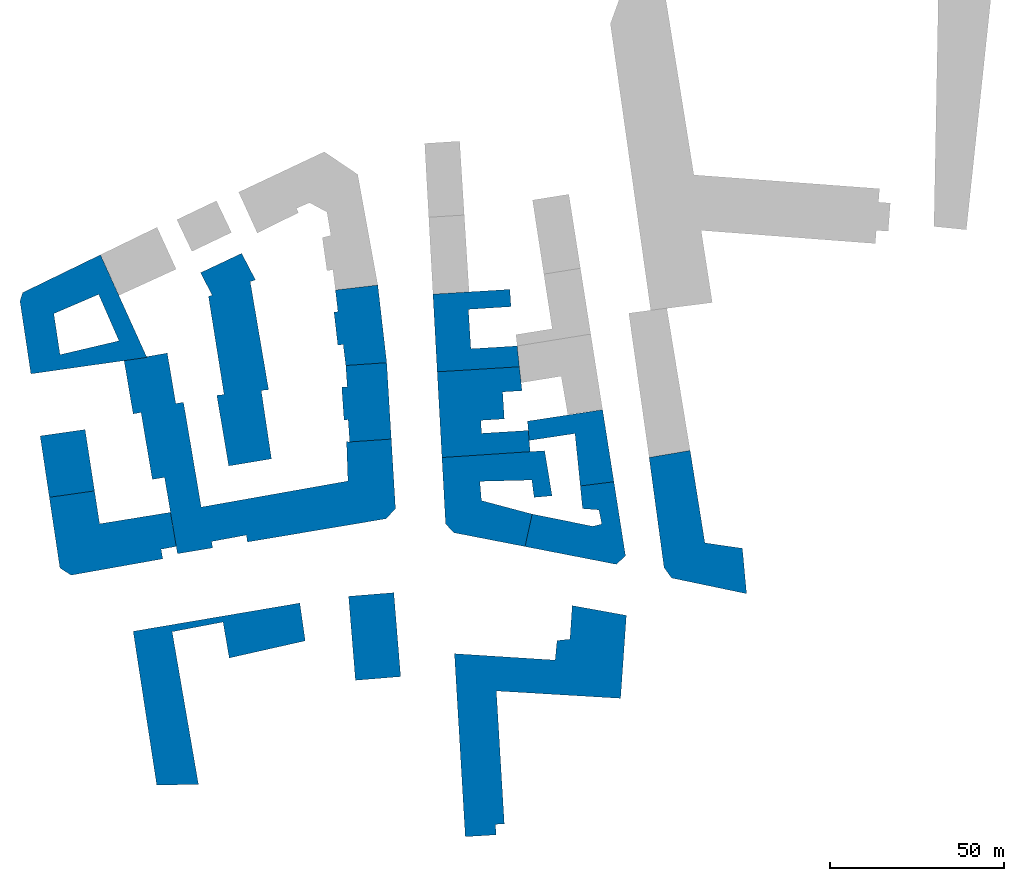
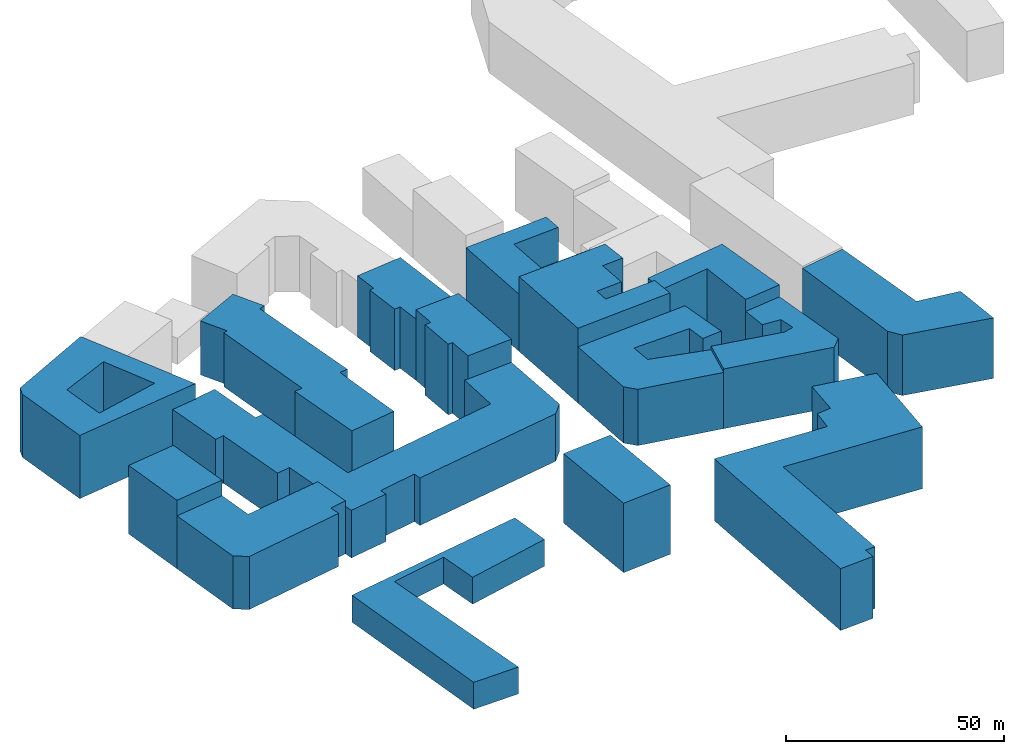
# One storey, part 1 of 2: 16 walls.
"""IFC2X3 building model written with IfcOpenShell, lengths in metres."""

from ifc_helpers import new_model, entity, si_unit, converted_unit, origin_with_axes, origin_2d_with_axis, place, context, subcontext, project, spatial, faceted_brep, element, save


model = new_model("IFC2X3")

# Units and contexts
model_context = context("Model", 3, precision=1e-05, world=origin_with_axes())
plan_context = context("Plan", 2, precision=1e-05, world=origin_2d_with_axis())
body_context = subcontext(model_context, "Body", "Model", "MODEL_VIEW")
ifc_project = project(units=[si_unit("AREAUNIT", "SQUARE_METRE"), si_unit("VOLUMEUNIT", "CUBIC_METRE"), si_unit("LENGTHUNIT", "METRE"), converted_unit("PLANEANGLEUNIT", "degree", entity("IfcReal", 0.0174532925199433), si_unit("PLANEANGLEUNIT", "RADIAN"), dimensions=[0, 0, 0, 0, 0, 0, 0])], contexts=[model_context, plan_context])

# Site, building, storey
site_placement = place(None, origin_with_axes())
site = spatial("IfcSite", under=ifc_project, at=site_placement, CompositionType="ELEMENT")
building_placement = place(site_placement, origin_with_axes())
building = spatial("IfcBuilding", under=site, at=building_placement, Name="Building", CompositionType="ELEMENT")
storey_placement = place(building_placement, origin_with_axes())
storey = spatial("IfcBuildingStorey", under=building, at=storey_placement, Name="Storey", CompositionType="ELEMENT")

# Walls
wall_1_placement = place(storey_placement, origin_with_axes())
element("IfcWall", 1, at=wall_1_placement, inside=storey, Name="map_2.buildings", context=body_context, shape_type="Brep", body=[
    faceted_brep([(58.7757415771484, -22.9065933227539, 0.0), (59.4299621582031, -29.4299068450928, 0.0), (59.4299621582031, -29.4299068450928, 16.7430152893066), (58.7757415771484, -22.9065933227539, 16.7430152893066), (68.449333190918, -21.7042007446289, 0.0), (68.449333190918, -21.7042007446289, 16.7430152893066), (71.7769470214844, -42.9439086914062, 16.7430152893066), (71.7769470214844, -42.9439086914062, 0.0), (69.2107620239258, -45.4709014892578, 16.7430152893066), (69.2107620239258, -45.4709014892578, 0.0), (42.8817558288574, -40.3394088745117, 0.0), (42.8817558288574, -40.3394088745117, 16.7430152893066), (44.9384117126465, -30.999683380127, 0.0), (44.9384117126465, -30.999683380127, 16.7430152893066), (62.3862113952637, -34.5060348510742, 0.0), (62.3862113952637, -34.5060348510742, 16.7430152893066), (64.9712905883789, -33.8603439331055, 0.0), (64.9712905883789, -33.8603439331055, 16.7430152893066), (64.140983581543, -29.7971935272217, 16.7430152893066), (64.140983581543, -29.7971935272217, 0.0)], [[[0, 1, 2, 3]], [[4, 0, 3, 5]], [[4, 6, 7]], [[7, 8, 9]], [[10, 9, 8, 11]], [[12, 10, 11, 13]], [[14, 12, 13, 15]], [[16, 14, 15, 17]], [[16, 18, 19]], [[1, 19, 18, 2]], [[4, 5, 6]], [[7, 6, 8]], [[16, 17, 18]]]),
    faceted_brep([(58.7757415771484, -22.9065933227539, 16.7430152893066), (59.4299621582031, -29.4299068450928, 16.7430152893066), (64.140983581543, -29.7971935272217, 16.7430152893066), (64.9712905883789, -33.8603439331055, 16.7430152893066), (62.3862113952637, -34.5060348510742, 16.7430152893066), (44.9384117126465, -30.999683380127, 16.7430152893066), (42.8817558288574, -40.3394088745117, 16.7430152893066), (69.2107620239258, -45.4709014892578, 16.7430152893066), (71.7769470214844, -42.9439086914062, 16.7430152893066), (68.449333190918, -21.7042007446289, 16.7430152893066)], [[[0, 1, 2, 3, 4, 5, 6, 7, 8, 9]]]),
])
wall_2_placement = place(storey_placement, origin_with_axes())
element("IfcWall", 2, at=wall_2_placement, inside=storey, Name="map_2.buildings", context=body_context, shape_type="Brep", body=[
    faceted_brep([(5.13064289093018, -53.597770690918, 0.0), (-7.88290691375732, -54.6553001403809, 0.0), (-7.88290691375732, -54.6553001403809, 19.4719886779785), (5.13064289093018, -53.597770690918, 19.4719886779785), (7.09938287734985, -77.7652282714844, 0.0), (7.09938287734985, -77.7652282714844, 19.4719886779785), (-5.90794897079468, -78.8227615356445, 19.4719886779785), (-5.90794897079468, -78.8227615356445, 0.0)], [[[0, 1, 2, 3]], [[4, 0, 3, 5]], [[4, 6, 7]], [[1, 7, 6, 2]], [[4, 5, 6]]]),
    faceted_brep([(5.13064289093018, -53.597770690918, 19.4719886779785), (-5.90794897079468, -78.8227615356445, 19.4719886779785), (7.09938287734985, -77.7652282714844, 19.4719886779785), (-7.88290691375732, -54.6553001403809, 19.4719886779785)], [[[0, 1, 2]], [[0, 3, 1]]]),
])
wall_3_placement = place(storey_placement, origin_with_axes())
element("IfcWall", 3, at=wall_3_placement, inside=storey, Name="map_2.buildings", context=body_context, shape_type="Brep", body=[
    faceted_brep([(-46.9925994873047, -40.7178535461426, 0.0), (-57.1065559387207, -42.4097900390625, 13.334171295166), (-57.1065559387207, -42.4097900390625, 0.0), (-60.8234977722168, -20.4352722167969, 13.334171295166), (-60.8234977722168, -20.4352722167969, 0.0), (-64.3331756591797, -21.0252151489258, 0.0), (-64.3331756591797, -21.0252151489258, 13.334171295166), (-67.5909576416016, -1.7780259847641, 13.334171295166), (-67.5909576416016, -1.7780259847641, 0.0), (-69.8678359985352, -2.16760802268982, 0.0), (-69.8678359985352, -2.16760802268982, 13.334171295166), (-72.4589385986328, 13.149995803833, 0.0), (-72.4589385986328, 13.149995803833, 13.334171295166), (-60.0430793762207, 15.3316698074341, 0.0), (-60.0430793762207, 15.3316698074341, 13.334171295166), (-57.5902976989746, 0.804443001747131, 0.0), (-57.5902976989746, 0.804443001747131, 13.334171295166), (-55.3826065063477, 1.17176902294159, 0.0), (-55.3826065063477, 1.17176902294159, 13.334171295166), (-50.2757186889648, -28.9847431182861, 0.0), (-50.2757186889648, -28.9847431182861, 13.334171295166), (-8.07153987884521, -21.4820919036865, 0.0), (-8.07153987884521, -21.4820919036865, 13.334171295166), (-8.46777057647705, -10.1275024414062, 0.0), (-8.46777057647705, -10.1275024414062, 13.334171295166), (-7.56205177307129, -10.238823890686, 0.0), (-7.56205177307129, -10.238823890686, 13.334171295166), (4.40727519989014, -9.41506385803223, 0.0), (4.40727519989014, -9.41506385803223, 13.334171295166), (5.61492490768433, -29.4080429077148, 0.0), (5.61492490768433, -29.4080429077148, 13.334171295166), (2.92920708656311, -32.3357467651367, 13.334171295166), (2.92920708656311, -32.3357467651367, 0.0), (-36.9792900085449, -39.0370254516602, 13.334171295166), (-36.9792900085449, -39.0370254516602, 0.0), (-37.2874717712402, -37.0444030761719, 13.334171295166), (-37.2874717712402, -37.0444030761719, 0.0), (-47.30078125, -38.8922119140625, 13.334171295166), (-47.30078125, -38.8922119140625, 0.0), (-46.9925994873047, -40.7178535461426, 13.334171295166)], [[[0, 1, 2]], [[2, 3, 4]], [[5, 4, 3, 6]], [[5, 7, 8]], [[9, 8, 7, 10]], [[11, 9, 10, 12]], [[13, 11, 12, 14]], [[15, 13, 14, 16]], [[17, 15, 16, 18]], [[19, 17, 18, 20]], [[21, 19, 20, 22]], [[23, 21, 22, 24]], [[25, 23, 24, 26]], [[27, 25, 26, 28]], [[29, 27, 28, 30]], [[29, 31, 32]], [[32, 33, 34]], [[34, 35, 36]], [[36, 37, 38]], [[38, 39, 0]], [[0, 39, 1]], [[2, 1, 3]], [[5, 6, 7]], [[29, 30, 31]], [[32, 31, 33]], [[34, 33, 35]], [[36, 35, 37]], [[38, 37, 39]]]),
    faceted_brep([(-47.30078125, -38.8922119140625, 13.334171295166), (-37.2874717712402, -37.0444030761719, 13.334171295166), (-50.2757186889648, -28.9847431182861, 13.334171295166), (-60.8234977722168, -20.4352722167969, 13.334171295166), (-57.1065559387207, -42.4097900390625, 13.334171295166), (-46.9925994873047, -40.7178535461426, 13.334171295166), (-67.5909576416016, -1.7780259847641, 13.334171295166), (-64.3331756591797, -21.0252151489258, 13.334171295166), (-72.4589385986328, 13.149995803833, 13.334171295166), (-69.8678359985352, -2.16760802268982, 13.334171295166), (-57.5902976989746, 0.804443001747131, 13.334171295166), (-60.0430793762207, 15.3316698074341, 13.334171295166), (-55.3826065063477, 1.17176902294159, 13.334171295166), (-7.56205177307129, -10.238823890686, 13.334171295166), (-8.46777057647705, -10.1275024414062, 13.334171295166), (-8.07153987884521, -21.4820919036865, 13.334171295166), (4.40727519989014, -9.41506385803223, 13.334171295166), (5.61492490768433, -29.4080429077148, 13.334171295166), (2.92920708656311, -32.3357467651367, 13.334171295166), (-36.9792900085449, -39.0370254516602, 13.334171295166)], [[[0, 1, 2]], [[3, 4, 2]], [[4, 5, 0]], [[4, 0, 2]], [[6, 7, 3]], [[8, 9, 6]], [[10, 11, 6]], [[11, 8, 6]], [[2, 12, 3]], [[12, 10, 3]], [[13, 14, 15]], [[16, 13, 15]], [[10, 6, 3]], [[17, 16, 15]], [[17, 15, 18]], [[15, 2, 1]], [[19, 18, 15]], [[1, 19, 15]]]),
])
wall_4_placement = place(storey_placement, origin_with_axes())
element("IfcWall", 4, at=wall_4_placement, inside=storey, Name="map_2.buildings", context=body_context, shape_type="Brep", body=[
    faceted_brep([(-47.1427726745605, 31.9849071502686, 0.0), (-48.1868591308594, 31.6175632476807, 0.0), (-48.1868591308594, 31.6175632476807, 15.123309135437), (-47.1427726745605, 31.9849071502686, 15.123309135437), (-50.4762115478516, 38.4414749145508, 15.123309135437), (-50.4762115478516, 38.4414749145508, 0.0), (-38.6516304016113, 44.0184593200684, 15.123309135437), (-38.6516304016113, 44.0184593200684, 0.0), (-34.670352935791, 36.381908416748, 0.0), (-34.670352935791, 36.381908416748, 15.123309135437), (-36.1798706054688, 35.8587188720703, 15.123309135437), (-36.1798706054688, 35.8587188720703, 0.0), (-30.8967876434326, 4.80054187774658, 0.0), (-30.8967876434326, 4.80054187774658, 15.123309135437), (-33.010124206543, 4.56678676605225, 0.0), (-33.010124206543, 4.56678676605225, 15.123309135437), (-30.0729751586914, -15.114520072937, 0.0), (-30.0729751586914, -15.114520072937, 15.123309135437), (-42.3819808959961, -17.1404323577881, 0.0), (-42.3819808959961, -17.1404323577881, 15.123309135437), (-45.7907981872559, 3.17540788650513, 0.0), (-45.7907981872559, 3.17540788650513, 15.123309135437), (-43.7026176452637, 3.39802598953247, 0.0), (-43.7026176452637, 3.39802598953247, 15.123309135437)], [[[0, 1, 2, 3]], [[0, 4, 5]], [[5, 6, 7]], [[8, 7, 6, 9]], [[8, 10, 11]], [[12, 11, 10, 13]], [[14, 12, 13, 15]], [[16, 14, 15, 17]], [[18, 16, 17, 19]], [[20, 18, 19, 21]], [[22, 20, 21, 23]], [[22, 2, 1]], [[0, 3, 4]], [[5, 4, 6]], [[8, 9, 10]], [[22, 23, 2]]]),
    faceted_brep([(-33.010124206543, 4.56678676605225, 15.123309135437), (-36.1798706054688, 35.8587188720703, 15.123309135437), (-47.1427726745605, 31.9849071502686, 15.123309135437), (-48.1868591308594, 31.6175632476807, 15.123309135437), (-43.7026176452637, 3.39802598953247, 15.123309135437), (-45.7907981872559, 3.17540788650513, 15.123309135437), (-42.3819808959961, -17.1404323577881, 15.123309135437), (-30.0729751586914, -15.114520072937, 15.123309135437), (-30.8967876434326, 4.80054187774658, 15.123309135437), (-34.670352935791, 36.381908416748, 15.123309135437), (-38.6516304016113, 44.0184593200684, 15.123309135437), (-50.4762115478516, 38.4414749145508, 15.123309135437)], [[[0, 1, 2]], [[2, 3, 4]], [[4, 5, 6]], [[6, 7, 4]], [[7, 0, 4]], [[0, 8, 1]], [[1, 9, 10]], [[10, 11, 1]], [[11, 2, 1]], [[2, 4, 0]]]),
])
wall_5_placement = place(storey_placement, origin_with_axes())
element("IfcWall", 5, at=wall_5_placement, inside=storey, Name="map_2.buildings", context=body_context, shape_type="Brep", body=[
    faceted_brep([(82.8721542358398, -46.3500862121582, 0.0), (78.588249206543, -14.7020349502563, 16.9712829589844), (78.588249206543, -14.7020349502563, 0.0), (90.3751449584961, -12.6980562210083, 16.9712829589844), (90.3751449584961, -12.6980562210083, 0.0), (94.627571105957, -39.2810592651367, 16.9712829589844), (94.627571105957, -39.2810592651367, 0.0), (105.414543151855, -40.8504180908203, 0.0), (105.414543151855, -40.8504180908203, 16.9712829589844), (106.622497558594, -53.9081649780273, 16.9712829589844), (106.622497558594, -53.9081649780273, 0.0), (85.0421829223633, -49.3890686035156, 16.9712829589844), (85.0421829223633, -49.3890686035156, 0.0), (82.8721542358398, -46.3500862121582, 16.9712829589844)], [[[0, 1, 2]], [[2, 3, 4]], [[4, 5, 6]], [[7, 6, 5, 8]], [[7, 9, 10]], [[10, 11, 12]], [[12, 13, 0]], [[0, 13, 1]], [[2, 1, 3]], [[4, 3, 5]], [[7, 8, 9]], [[10, 9, 11]], [[12, 11, 13]]]),
    faceted_brep([(78.588249206543, -14.7020349502563, 16.9712829589844), (82.8721542358398, -46.3500862121582, 16.9712829589844), (85.0421829223633, -49.3890686035156, 16.9712829589844), (106.622497558594, -53.9081649780273, 16.9712829589844), (105.414543151855, -40.8504180908203, 16.9712829589844), (94.627571105957, -39.2810592651367, 16.9712829589844), (90.3751449584961, -12.6980562210083, 16.9712829589844)], [[[0, 1, 2, 3, 4, 5, 6]]]),
])
wall_6_placement = place(storey_placement, origin_with_axes())
element("IfcWall", 6, at=wall_6_placement, inside=storey, Name="map_2.buildings", context=body_context, shape_type="Brep", body=[
    faceted_brep([(44.9384117126465, -30.999683380127, 0.0), (42.8817558288574, -40.3394088745117, 15.7792825698853), (42.8817558288574, -40.3394088745117, 0.0), (22.3834133148193, -36.3543243408203, 0.0), (22.3834133148193, -36.3543243408203, 15.7792825698853), (20.0310344696045, -33.8162536621094, 0.0), (20.0310344696045, -33.8162536621094, 15.7792825698853), (18.9805641174316, -14.7249641418457, 15.7792825698853), (18.9805641174316, -14.7249641418457, 0.0), (48.5170745849609, -12.765513420105, 0.0), (48.5170745849609, -12.765513420105, 15.7792825698853), (50.6620178222656, -25.7342090606689, 15.7792825698853), (50.6620178222656, -25.7342090606689, 0.0), (45.4918594360352, -26.1906757354736, 0.0), (45.4918594360352, -26.1906757354736, 15.7792825698853), (44.8439636230469, -21.2035694122314, 15.7792825698853), (44.8439636230469, -21.2035694122314, 0.0), (29.8869876861572, -21.5821838378906, 15.7792825698853), (29.8869876861572, -21.5821838378906, 0.0), (30.3461761474609, -27.1147594451904, 0.0), (30.3461761474609, -27.1147594451904, 15.7792825698853), (44.9384117126465, -30.999683380127, 15.7792825698853)], [[[0, 1, 2]], [[3, 2, 1, 4]], [[5, 3, 4, 6]], [[5, 7, 8]], [[9, 8, 7, 10]], [[9, 11, 12]], [[13, 12, 11, 14]], [[13, 15, 16]], [[16, 17, 18]], [[19, 18, 17, 20]], [[19, 21, 0]], [[0, 21, 1]], [[5, 6, 7]], [[9, 10, 11]], [[13, 14, 15]], [[16, 15, 17]], [[19, 20, 21]]]),
    faceted_brep([(42.8817558288574, -40.3394088745117, 15.7792825698853), (44.9384117126465, -30.999683380127, 15.7792825698853), (30.3461761474609, -27.1147594451904, 15.7792825698853), (29.8869876861572, -21.5821838378906, 15.7792825698853), (44.8439636230469, -21.2035694122314, 15.7792825698853), (45.4918594360352, -26.1906757354736, 15.7792825698853), (50.6620178222656, -25.7342090606689, 15.7792825698853), (48.5170745849609, -12.765513420105, 15.7792825698853), (18.9805641174316, -14.7249641418457, 15.7792825698853), (20.0310344696045, -33.8162536621094, 15.7792825698853), (22.3834133148193, -36.3543243408203, 15.7792825698853)], [[[0, 1, 2, 3, 4, 5, 6, 7, 8, 9, 10]]]),
])
wall_7_placement = place(storey_placement, origin_with_axes())
element("IfcWall", 7, at=wall_7_placement, inside=storey, Name="map_2.buildings", context=body_context, shape_type="Brep", body=[
    faceted_brep([(70.3749923706055, -84.0096893310547, 0.0), (34.6362113952637, -81.883918762207, 17.3642425537109), (34.6362113952637, -81.883918762207, 0.0), (36.9260292053223, -120.122146606445, 17.3642425537109), (36.9260292053223, -120.122146606445, 0.0), (34.3786315917969, -120.266876220703, 17.3642425537109), (34.3786315917969, -120.266876220703, 0.0), (34.5610618591309, -123.283638000488, 17.3642425537109), (34.5610618591309, -123.283638000488, 0.0), (25.6923389434814, -123.818031311035, 17.3642425537109), (25.6923389434814, -123.818031311035, 0.0), (22.5785751342773, -71.1527938842773, 0.0), (22.5785751342773, -71.1527938842773, 17.3642425537109), (51.5431365966797, -73.0004577636719, 17.3642425537109), (51.5431365966797, -73.0004577636719, 0.0), (52.0902824401855, -67.3788146972656, 17.3642425537109), (52.0902824401855, -67.3788146972656, 0.0), (55.8138389587402, -66.9891510009766, 17.3642425537109), (55.8138389587402, -66.9891510009766, 0.0), (56.4552726745605, -57.3154792785645, 0.0), (56.4552726745605, -57.3154792785645, 17.3642425537109), (72.0413970947266, -60.142765045166, 17.3642425537109), (72.0413970947266, -60.142765045166, 0.0), (70.3749923706055, -84.0096893310547, 17.3642425537109)], [[[0, 1, 2]], [[2, 3, 4]], [[4, 5, 6]], [[6, 7, 8]], [[8, 9, 10]], [[11, 10, 9, 12]], [[11, 13, 14]], [[14, 15, 16]], [[16, 17, 18]], [[19, 18, 17, 20]], [[19, 21, 22]], [[22, 23, 0]], [[0, 23, 1]], [[2, 1, 3]], [[4, 3, 5]], [[6, 5, 7]], [[8, 7, 9]], [[11, 12, 13]], [[14, 13, 15]], [[16, 15, 17]], [[19, 20, 21]], [[22, 21, 23]]]),
    faceted_brep([(51.5431365966797, -73.0004577636719, 17.3642425537109), (22.5785751342773, -71.1527938842773, 17.3642425537109), (34.6362113952637, -81.883918762207, 17.3642425537109), (70.3749923706055, -84.0096893310547, 17.3642425537109), (72.0413970947266, -60.142765045166, 17.3642425537109), (55.8138389587402, -66.9891510009766, 17.3642425537109), (56.4552726745605, -57.3154792785645, 17.3642425537109), (52.0902824401855, -67.3788146972656, 17.3642425537109), (34.3786315917969, -120.266876220703, 17.3642425537109), (36.9260292053223, -120.122146606445, 17.3642425537109), (25.6923389434814, -123.818031311035, 17.3642425537109), (34.5610618591309, -123.283638000488, 17.3642425537109)], [[[0, 1, 2]], [[3, 4, 5]], [[4, 6, 5]], [[5, 7, 0]], [[8, 9, 2]], [[3, 5, 0]], [[1, 10, 2]], [[10, 11, 8]], [[10, 8, 2]], [[3, 0, 2]]]),
])
wall_8_placement = place(storey_placement, origin_with_axes())
element("IfcWall", 8, at=wall_8_placement, inside=storey, Name="map_2.buildings", context=body_context, shape_type="Brep", body=[
    faceted_brep([(18.9805641174316, -14.7249641418457, 0.0), (44.3532829284668, -13.0438566207886, 0.0), (44.3532829284668, -13.0438566207886, 20.9919261932373), (18.9805641174316, -14.7249641418457, 20.9919261932373), (17.6218852996826, 9.93229675292969, 20.9919261932373), (17.6218852996826, 9.93229675292969, 0.0), (41.2648010253906, 11.3907413482666, 0.0), (41.2648010253906, 11.3907413482666, 20.9919261932373), (42.0070495605469, 4.50007200241089, 20.9919261932373), (42.0070495605469, 4.50007200241089, 0.0), (36.434383392334, 4.14379978179932, 0.0), (36.434383392334, 4.14379978179932, 20.9919261932373), (36.9187545776367, -3.61516499519348, 20.9919261932373), (36.9187545776367, -3.61516499519348, 0.0), (30.1510353088379, -4.03822994232178, 0.0), (30.1510353088379, -4.03822994232178, 20.9919261932373), (30.3837795257568, -7.76743221282959, 20.9919261932373), (30.3837795257568, -7.76743221282959, 0.0), (43.8248825073242, -6.93242216110229, 0.0), (43.8248825073242, -6.93242216110229, 20.9919261932373)], [[[0, 1, 2, 3]], [[0, 4, 5]], [[6, 5, 4, 7]], [[6, 8, 9]], [[10, 9, 8, 11]], [[10, 12, 13]], [[14, 13, 12, 15]], [[14, 16, 17]], [[18, 17, 16, 19]], [[18, 2, 1]], [[0, 3, 4]], [[6, 7, 8]], [[10, 11, 12]], [[14, 15, 16]], [[18, 19, 2]]]),
    faceted_brep([(18.9805641174316, -14.7249641418457, 20.9919261932373), (30.3837795257568, -7.76743221282959, 20.9919261932373), (30.1510353088379, -4.03822994232178, 20.9919261932373), (44.3532829284668, -13.0438566207886, 20.9919261932373), (43.8248825073242, -6.93242216110229, 20.9919261932373), (41.2648010253906, 11.3907413482666, 20.9919261932373), (17.6218852996826, 9.93229675292969, 20.9919261932373), (36.434383392334, 4.14379978179932, 20.9919261932373), (42.0070495605469, 4.50007200241089, 20.9919261932373), (36.9187545776367, -3.61516499519348, 20.9919261932373)], [[[0, 1, 2]], [[0, 3, 1]], [[3, 4, 1]], [[5, 6, 7]], [[6, 0, 2]], [[7, 6, 2]], [[7, 8, 5]], [[2, 9, 7]]]),
])
wall_9_placement = place(storey_placement, origin_with_axes())
element("IfcWall", 9, at=wall_9_placement, inside=storey, Name="map_2.buildings", context=body_context, shape_type="Brep", body=[
    faceted_brep([(65.1972274780273, -0.976562023162842, 0.0), (68.449333190918, -21.7042007446289, 20.101921081543), (68.449333190918, -21.7042007446289, 0.0), (43.5984268188477, -4.26075601577759, 0.0), (65.1972274780273, -0.976562023162842, 20.101921081543), (58.7757415771484, -22.9065933227539, 0.0), (58.7757415771484, -22.9065933227539, 20.101921081543), (57.2660064697266, -7.82282209396362, 20.101921081543), (57.2660064697266, -7.82282209396362, 0.0), (44.0765037536621, -9.81559371948242, 0.0), (44.0765037536621, -9.81559371948242, 20.101921081543), (43.5984268188477, -4.26075601577759, 20.101921081543)], [[[0, 1, 2]], [[3, 4, 0]], [[5, 2, 1, 6]], [[5, 7, 8]], [[9, 8, 7, 10]], [[9, 11, 3]], [[0, 4, 1]], [[3, 11, 4]], [[5, 6, 7]], [[9, 10, 11]]]),
    faceted_brep([(65.1972274780273, -0.976562023162842, 20.101921081543), (43.5984268188477, -4.26075601577759, 20.101921081543), (44.0765037536621, -9.81559371948242, 20.101921081543), (57.2660064697266, -7.82282209396362, 20.101921081543), (58.7757415771484, -22.9065933227539, 20.101921081543), (68.449333190918, -21.7042007446289, 20.101921081543)], [[[0, 1, 2, 3, 4, 5]]]),
])
wall_10_placement = place(storey_placement, origin_with_axes())
element("IfcWall", 10, at=wall_10_placement, inside=storey, Name="map_2.buildings", context=body_context, shape_type="Brep", body=[
    faceted_brep([(40.6231956481934, 17.3685932159424, 0.0), (41.2648010253906, 11.3907413482666, 16.0378398895264), (41.2648010253906, 11.3907413482666, 0.0), (17.6218852996826, 9.93229675292969, 0.0), (17.6218852996826, 9.93229675292969, 16.0378398895264), (16.3953113555908, 32.274112701416, 0.0), (16.3953113555908, 32.274112701416, 16.0378398895264), (38.5223007202148, 33.654613494873, 16.0378398895264), (38.5223007202148, 33.654613494873, 0.0), (38.8368263244629, 28.6786365509033, 16.0378398895264), (38.8368263244629, 28.6786365509033, 0.0), (26.5908660888672, 27.9104404449463, 0.0), (26.5908660888672, 27.9104404449463, 16.0378398895264), (27.3016700744629, 16.5558567047119, 0.0), (27.3016700744629, 16.5558567047119, 16.0378398895264), (40.6231956481934, 17.3685932159424, 16.0378398895264)], [[[0, 1, 2]], [[3, 2, 1, 4]], [[5, 3, 4, 6]], [[5, 7, 8]], [[8, 9, 10]], [[11, 10, 9, 12]], [[13, 11, 12, 14]], [[0, 13, 14, 15]], [[0, 15, 1]], [[5, 6, 7]], [[8, 7, 9]]]),
    faceted_brep([(27.3016700744629, 16.5558567047119, 16.0378398895264), (26.5908660888672, 27.9104404449463, 16.0378398895264), (16.3953113555908, 32.274112701416, 16.0378398895264), (17.6218852996826, 9.93229675292969, 16.0378398895264), (41.2648010253906, 11.3907413482666, 16.0378398895264), (40.6231956481934, 17.3685932159424, 16.0378398895264), (38.8368263244629, 28.6786365509033, 16.0378398895264), (38.5223007202148, 33.654613494873, 16.0378398895264)], [[[0, 1, 2]], [[3, 4, 0]], [[4, 5, 0]], [[6, 7, 1]], [[7, 2, 1]], [[3, 0, 2]]]),
])
wall_11_placement = place(storey_placement, origin_with_axes())
element("IfcWall", 11, at=wall_11_placement, inside=storey, Name="map_2.buildings", context=body_context, shape_type="Brep", body=[
    faceted_brep([(-93.9767837524414, -26.1676387786865, 0.0), (-80.9758605957031, -24.319995880127, 0.0), (-80.9758605957031, -24.319995880127, 19.2274875640869), (-93.9767837524414, -26.1676387786865, 19.2274875640869), (-96.6117935180664, -8.51231002807617, 19.2274875640869), (-96.6117935180664, -8.51231002807617, 0.0), (-83.6926879882812, -6.67580509185791, 0.0), (-83.6926879882812, -6.67580509185791, 19.2274875640869)], [[[0, 1, 2, 3]], [[0, 4, 5]], [[6, 5, 4, 7]], [[6, 2, 1]], [[0, 3, 4]], [[6, 7, 2]]]),
    faceted_brep([(-93.9767837524414, -26.1676387786865, 19.2274875640869), (-80.9758605957031, -24.319995880127, 19.2274875640869), (-83.6926879882812, -6.67580509185791, 19.2274875640869), (-96.6117935180664, -8.51231002807617, 19.2274875640869)], [[[0, 1, 2, 3]]]),
])
wall_12_placement = place(storey_placement, origin_with_axes())
element("IfcWall", 12, at=wall_12_placement, inside=storey, Name="map_2.buildings", context=body_context, shape_type="Brep", body=[
    faceted_brep([(-11.6691188812256, 33.465217590332, 0.0), (-10.9458246231079, 27.2535877227783, 0.0), (-10.9458246231079, 27.2535877227783, 17.2276725769043), (-11.6691188812256, 33.465217590332, 17.2276725769043), (0.526516020298004, 34.8900909423828, 17.2276725769043), (0.526516020298004, 34.8900909423828, 0.0), (3.08641910552979, 12.5594024658203, 0.0), (3.08641910552979, 12.5594024658203, 17.2276725769043), (-8.68786716461182, 11.7467775344849, 0.0), (-8.68786716461182, 11.7467775344849, 17.2276725769043), (-9.42374706268311, 17.7914276123047, 0.0), (-9.42374706268311, 17.7914276123047, 17.2276725769043), (-10.9710073471069, 17.6133193969727, 17.2276725769043), (-10.9710073471069, 17.6133193969727, 0.0), (-12.0842533111572, 27.1200084686279, 0.0), (-12.0842533111572, 27.1200084686279, 17.2276725769043)], [[[0, 1, 2, 3]], [[0, 4, 5]], [[6, 5, 4, 7]], [[8, 6, 7, 9]], [[10, 8, 9, 11]], [[10, 12, 13]], [[14, 13, 12, 15]], [[14, 2, 1]], [[0, 3, 4]], [[10, 11, 12]], [[14, 15, 2]]]),
    faceted_brep([(-11.6691188812256, 33.465217590332, 17.2276725769043), (-10.9458246231079, 27.2535877227783, 17.2276725769043), (-12.0842533111572, 27.1200084686279, 17.2276725769043), (-10.9710073471069, 17.6133193969727, 17.2276725769043), (-9.42374706268311, 17.7914276123047, 17.2276725769043), (-8.68786716461182, 11.7467775344849, 17.2276725769043), (3.08641910552979, 12.5594024658203, 17.2276725769043), (0.526516020298004, 34.8900909423828, 17.2276725769043)], [[[0, 1, 2, 3, 4, 5, 6, 7]]]),
])
wall_13_placement = place(storey_placement, origin_with_axes())
element("IfcWall", 13, at=wall_13_placement, inside=storey, Name="map_2.buildings", context=body_context, shape_type="Brep", body=[
    faceted_brep([(-8.68786716461182, 11.7467775344849, 0.0), (-8.26018047332764, 5.61307287216187, 0.0), (-8.26018047332764, 5.61307287216187, 19.8262386322021), (-8.68786716461182, 11.7467775344849, 19.8262386322021), (3.08641910552979, 12.5594024658203, 0.0), (3.08641910552979, 12.5594024658203, 19.8262386322021), (4.40727519989014, -9.41506385803223, 0.0), (4.40727519989014, -9.41506385803223, 19.8262386322021), (-7.56205177307129, -10.238823890686, 0.0), (-7.56205177307129, -10.238823890686, 19.8262386322021), (-8.00232028961182, -3.83795189857483, 0.0), (-8.00232028961182, -3.83795189857483, 19.8262386322021), (-9.19736385345459, -3.91587400436401, 0.0), (-9.19736385345459, -3.91587400436401, 19.8262386322021), (-9.84518241882324, 5.50175714492798, 0.0), (-9.84518241882324, 5.50175714492798, 19.8262386322021)], [[[0, 1, 2, 3]], [[4, 0, 3, 5]], [[6, 4, 5, 7]], [[8, 6, 7, 9]], [[10, 8, 9, 11]], [[12, 10, 11, 13]], [[14, 12, 13, 15]], [[1, 14, 15, 2]]]),
    faceted_brep([(-8.68786716461182, 11.7467775344849, 19.8262386322021), (-8.26018047332764, 5.61307287216187, 19.8262386322021), (-9.84518241882324, 5.50175714492798, 19.8262386322021), (-9.19736385345459, -3.91587400436401, 19.8262386322021), (-8.00232028961182, -3.83795189857483, 19.8262386322021), (-7.56205177307129, -10.238823890686, 19.8262386322021), (4.40727519989014, -9.41506385803223, 19.8262386322021), (3.08641910552979, 12.5594024658203, 19.8262386322021)], [[[0, 1, 2, 3, 4, 5, 6, 7]]]),
])
wall_14_placement = place(storey_placement, origin_with_axes())
element("IfcWall", 14, at=wall_14_placement, inside=storey, Name="map_2.buildings", context=body_context, shape_type="Brep", body=[
    faceted_brep([(-79.5231094360352, -33.7933120727539, 0.0), (-59.1254081726074, -30.4874458312988, 14.873908996582), (-59.1254081726074, -30.4874458312988, 0.0), (-57.4650421142578, -40.3058471679688, 14.873908996582), (-57.4650421142578, -40.3058471679688, 0.0), (-61.817569732666, -41.1184196472168, 0.0), (-61.817569732666, -41.1184196472168, 14.873908996582), (-61.3395843505859, -43.879150390625, 14.873908996582), (-61.3395843505859, -43.879150390625, 0.0), (-87.7063674926758, -48.5763816833496, 14.873908996582), (-87.7063674926758, -48.5763816833496, 0.0), (-90.932975769043, -46.5169067382812, 0.0), (-90.932975769043, -46.5169067382812, 14.873908996582), (-93.9767837524414, -26.1676387786865, 14.873908996582), (-93.9767837524414, -26.1676387786865, 0.0), (-80.9758605957031, -24.319995880127, 0.0), (-80.9758605957031, -24.319995880127, 14.873908996582), (-79.5231094360352, -33.7933120727539, 14.873908996582)], [[[0, 1, 2]], [[2, 3, 4]], [[5, 4, 3, 6]], [[5, 7, 8]], [[8, 9, 10]], [[11, 10, 9, 12]], [[11, 13, 14]], [[15, 14, 13, 16]], [[15, 17, 0]], [[0, 17, 1]], [[2, 1, 3]], [[5, 6, 7]], [[8, 7, 9]], [[11, 12, 13]], [[15, 16, 17]]]),
    faceted_brep([(-59.1254081726074, -30.4874458312988, 14.873908996582), (-79.5231094360352, -33.7933120727539, 14.873908996582), (-80.9758605957031, -24.319995880127, 14.873908996582), (-93.9767837524414, -26.1676387786865, 14.873908996582), (-90.932975769043, -46.5169067382812, 14.873908996582), (-87.7063674926758, -48.5763816833496, 14.873908996582), (-61.3395843505859, -43.879150390625, 14.873908996582), (-61.817569732666, -41.1184196472168, 14.873908996582), (-57.4650421142578, -40.3058471679688, 14.873908996582)], [[[0, 1, 2, 3, 4, 5, 6, 7, 8]]]),
])
wall_15_placement = place(storey_placement, origin_with_axes())
element("IfcWall", 15, at=wall_15_placement, inside=storey, Name="map_2.buildings", context=body_context, shape_type="Brep", body=[
    faceted_brep([(-51.0754508972168, -108.756278991699, 0.0), (-63.0764999389648, -108.978759765625, 7.54079914093018), (-63.0764999389648, -108.978759765625, 0.0), (-69.849967956543, -64.7180328369141, 7.54079914093018), (-69.849967956543, -64.7180328369141, 0.0), (-21.915412902832, -56.592212677002, 7.54079914093018), (-21.915412902832, -56.592212677002, 0.0), (-20.349308013916, -67.468132019043, 7.54079914093018), (-20.349308013916, -67.468132019043, 0.0), (-42.2189788818359, -72.3994293212891, 7.54079914093018), (-42.2189788818359, -72.3994293212891, 0.0), (-43.9988899230957, -62.0578308105469, 7.54079914093018), (-43.9988899230957, -62.0578308105469, 0.0), (-58.6415596008301, -64.8517761230469, 7.54079914093018), (-58.6415596008301, -64.8517761230469, 0.0), (-51.0754508972168, -108.756278991699, 7.54079914093018)], [[[0, 1, 2]], [[2, 3, 4]], [[4, 5, 6]], [[6, 7, 8]], [[8, 9, 10]], [[10, 11, 12]], [[12, 13, 14]], [[14, 15, 0]], [[0, 15, 1]], [[2, 1, 3]], [[4, 3, 5]], [[6, 5, 7]], [[8, 7, 9]], [[10, 9, 11]], [[12, 11, 13]], [[14, 13, 15]]]),
    faceted_brep([(-63.0764999389648, -108.978759765625, 7.54079914093018), (-51.0754508972168, -108.756278991699, 7.54079914093018), (-58.6415596008301, -64.8517761230469, 7.54079914093018), (-43.9988899230957, -62.0578308105469, 7.54079914093018), (-42.2189788818359, -72.3994293212891, 7.54079914093018), (-20.349308013916, -67.468132019043, 7.54079914093018), (-21.915412902832, -56.592212677002, 7.54079914093018), (-69.849967956543, -64.7180328369141, 7.54079914093018)], [[[0, 1, 2, 3, 4, 5, 6, 7]]]),
])
wall_16_placement = place(storey_placement, origin_with_axes())
element("IfcWall", 16, at=wall_16_placement, inside=storey, Name="map_2.buildings", context=body_context, shape_type="Brep", body=[
    faceted_brep([(-99.2845153808594, 9.34339618682861, 0.0), (-65.9113693237305, 14.0738439559937, 0.0), (-65.9113693237305, 14.0738439559937, 17.7257061004639), (-99.2845153808594, 9.34339618682861, 17.7257061004639), (-79.2701110839844, 43.6071281433105, 0.0), (-102.416290283203, 30.2826652526855, 17.7257061004639), (-102.416290283203, 30.2826652526855, 0.0), (-101.642608642578, 32.7205429077148, 17.7257061004639), (-101.642608642578, 32.7205429077148, 0.0), (-79.2701110839844, 43.6071281433105, 17.7257061004639), (-92.6862640380859, 26.6868286132812, 0.0), (-90.9065399169922, 14.8535289764404, 17.7257061004639), (-90.9065399169922, 14.8535289764404, 0.0), (-79.7797775268555, 32.2080192565918, 0.0), (-92.6862640380859, 26.6868286132812, 17.7257061004639), (-73.9369201660156, 18.8495788574219, 0.0), (-79.7797775268555, 32.2080192565918, 17.7257061004639), (-73.9369201660156, 18.8495788574219, 17.7257061004639)], [[[0, 1, 2, 3]], [[4, 2, 1]], [[0, 5, 6]], [[6, 7, 8]], [[8, 9, 4]], [[10, 11, 12]], [[13, 14, 10]], [[15, 16, 13]], [[15, 12, 11, 17]], [[4, 9, 2]], [[0, 3, 5]], [[6, 5, 7]], [[8, 7, 9]], [[10, 14, 11]], [[13, 16, 14]], [[15, 17, 16]]]),
    faceted_brep([(-99.2845153808594, 9.34339618682861, 17.7257061004639), (-65.9113693237305, 14.0738439559937, 17.7257061004639), (-90.9065399169922, 14.8535289764404, 17.7257061004639), (-79.7797775268555, 32.2080192565918, 17.7257061004639), (-79.2701110839844, 43.6071281433105, 17.7257061004639), (-92.6862640380859, 26.6868286132812, 17.7257061004639), (-101.642608642578, 32.7205429077148, 17.7257061004639), (-102.416290283203, 30.2826652526855, 17.7257061004639), (-73.9369201660156, 18.8495788574219, 17.7257061004639)], [[[0, 1, 2]], [[3, 1, 4]], [[2, 5, 0]], [[5, 6, 7]], [[7, 0, 5]], [[8, 2, 1]], [[4, 6, 5]], [[3, 8, 1]], [[4, 5, 3]]]),
])

save(model, "model.ifc")
